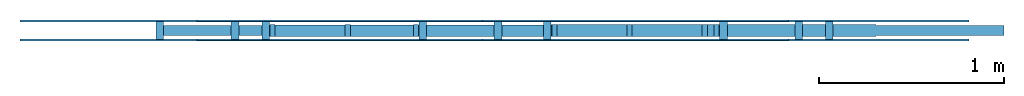
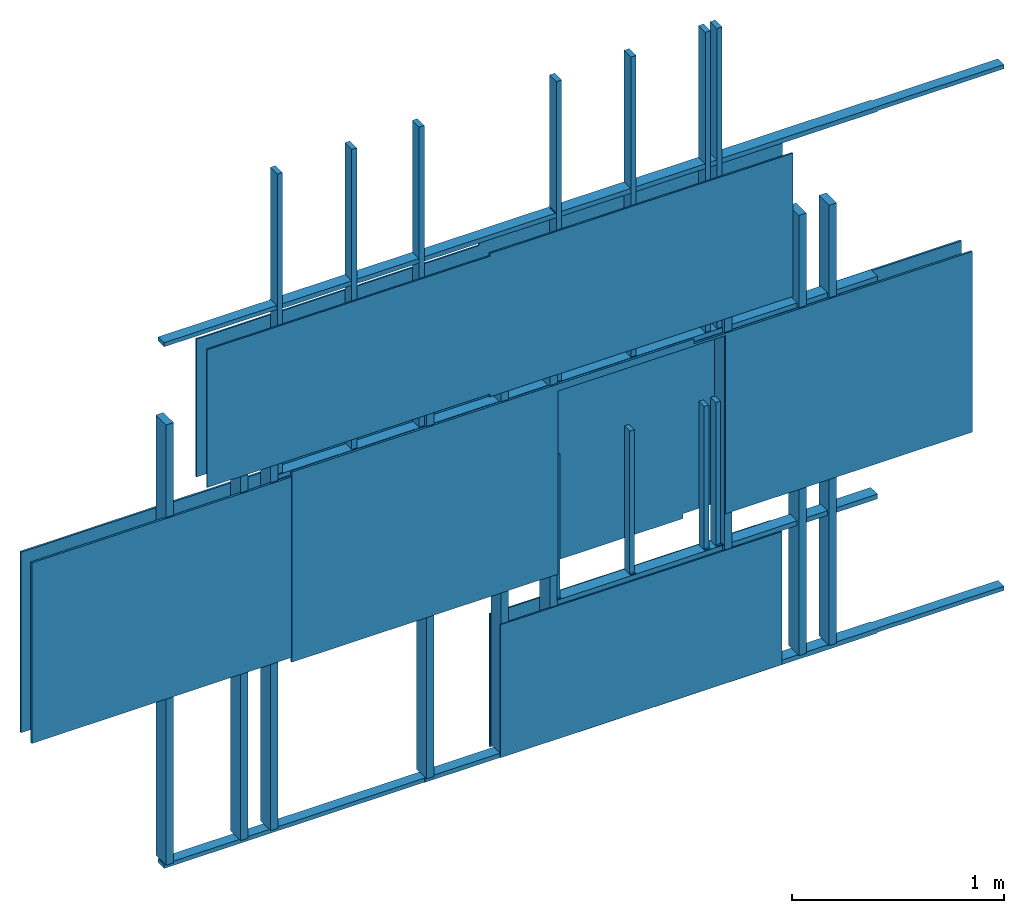
# Not in any storey: 2 building element parts, 2 members, 2 openings, 2 elements without a shape of their own.
"""IFC4 model written with IfcOpenShell, lengths in inches."""

from ifc_helpers import new_model, entity, si_unit, converted_unit, frame, frame_2d, origin, place, context, project, spatial, rectangle, extrude, source, transform, mapped, material, material_profile, profile_set, profile_usage, type_object, type_shapes, element, aggregate, save


model = new_model("IFC4")

# Units and contexts
model_context = context("Model", 3, precision=1e-05, world=origin())
plan_context = context("Plan", 2, precision=1e-05, world=origin())
ifc_project = project(units=[converted_unit("AREAUNIT", "square inch", entity("IfcAreaMeasure", 0.0006452), si_unit("AREAUNIT", "SQUARE_METRE"), dimensions=[2, 0, 0, 0, 0, 0, 0]), converted_unit("LENGTHUNIT", "inch", entity("IfcLengthMeasure", 0.0254), si_unit("LENGTHUNIT", "METRE"), dimensions=[1, 0, 0, 0, 0, 0, 0]), converted_unit("MASSUNIT", "pound", entity("IfcMassMeasure", 0.45359237), si_unit("MASSUNIT", "GRAM", prefix="KILO"), dimensions=[0, 1, 0, 0, 0, 0, 0]), converted_unit("PLANEANGLEUNIT", "degree", entity("IfcPlaneAngleMeasure", 0.0174532925199433), si_unit("PLANEANGLEUNIT", "RADIAN"), dimensions=[0, 0, 0, 0, 0, 0, 0]), converted_unit("VOLUMEUNIT", "cubic inch", entity("IfcVolumeMeasure", 1.639e-05), si_unit("VOLUMEUNIT", "CUBIC_METRE"), dimensions=[3, 0, 0, 0, 0, 0, 0])], contexts=[model_context, plan_context])

# Site
site_placement = place(None, origin())
site = spatial("IfcSite", under=ifc_project, at=site_placement, CompositionType="ELEMENT")

# Wall, openings, assembly, members, building element parts
wall_type = type_object("IfcWallType", Name="Wood Framed Wall", PredefinedType="NOTDEFINED")
wall_placement = place(site_placement, frame((48.0, 48.0, 0.0), z_axis=(0.0, 0.0, 1.0), x_axis=(1.0, 0.0, 0.0)))
wall = element("IfcWallElementedCase", 1, at=wall_placement, inside=site, type_object=wall_type, Name="Wall #1", PredefinedType="MOVABLE")
opening_1_placement = place(wall_placement, frame((24.0, -2.25, 0.0)))
element("IfcOpeningElement", 2, at=opening_1_placement, cuts=wall, context=model_context, shape_type="SweptSolid", body=[
    extrude(rectangle(XDim=32.0, YDim=80.0, at=frame_2d((-16.0, 40.0))), frame((0.0, 0.0, 0.0), z_axis=(0.0, 1.0, 0.0), x_axis=(-1.0, 0.0, 0.0)), (0.0, 0.0, 1.0), 1.5),
])
opening_2_placement = place(wall_placement, frame((84.0, 0.0, 32.0), z_axis=(0.0, -1.0, 0.0), x_axis=(1.0, 0.0, 0.0)))
element("IfcOpeningElement", 3, at=opening_2_placement, cuts=wall, PredefinedType="OPENING", context=model_context, shape_type="SweptSolid", body=[
    extrude(rectangle(XDim=36.0, YDim=48.0), frame((18.0, 24.0, -1.5)), (0.0, 0.0, 1.0), 1.5),
])
element_assembly_type = type_object("IfcElementAssemblyType", Name="Wood Stud Frame", PredefinedType="NOTDEFINED")
assembly_placement = place(wall_placement, frame((0.0, 0.5, 0.0), z_axis=(0.0, -1.0, 0.0), x_axis=(1.0, 0.0, 0.0)))
assembly = element("IfcElementAssembly", 4, at=assembly_placement, type_object=element_assembly_type, Name="Frame", PredefinedType="BRACED_FRAME")
ifc_material_1 = material(Name="Southern Pine")
ifc_material_profile_1 = material_profile(ifc_material_1, rectangle(XDim=3.5, YDim=1.5))
ifc_profile_set_1 = profile_set([ifc_material_profile_1])
ifc_profile_usage_1 = profile_usage(ifc_profile_set_1)
ifc_material_2 = material(Name="Southern Pine", Category="Wood")
ifc_material_profile_2 = material_profile(ifc_material_2, rectangle(XDim=1.5, YDim=3.5))
ifc_profile_set_2 = profile_set([ifc_material_profile_2], Name="2x4 Lumber")
member_type_1 = type_object("IfcMemberType", Name="Wood Track", PredefinedType="PLATE", material=ifc_profile_set_2)
shared_shape_1 = source(origin(), model_context, "Body", "SweptSolid", [
    extrude(rectangle(XDim=1.5, YDim=3.5), frame((0.0, 0.0, 0.0), z_axis=(1.0, 0.0, 0.0), x_axis=(0.0, 1.0, 0.0)), (0.0, 0.0, 1.0), 96.0),
])
type_shapes(member_type_1, [shared_shape_1])
member_1_placement = place(assembly_placement, origin())
member_1 = element("IfcMember", 5, at=member_1_placement, type_object=member_type_1, material=ifc_profile_usage_1, Name="Track", PredefinedType="PLATE", context=model_context, shape_type="MappedRepresentation", body=[
    mapped(shared_shape_1, transform((0.0, 0.75, -1.75), scale=0.25, scale2=1.0, scale3=1.0, uniform=False)),
    mapped(shared_shape_1, transform((0.0, 119.25, -1.75), scale=0.25, scale2=1.0, scale3=1.0, uniform=False)),
    mapped(shared_shape_1, transform((24.0, 80.75, -1.75), scale=0.333333333333333, scale2=1.0, scale3=1.0, uniform=False)),
    mapped(shared_shape_1, transform((24.0, 119.25, -1.75), scale=0.333333333333333, scale2=1.0, scale3=1.0, uniform=False)),
    mapped(shared_shape_1, transform((56.0, 0.75, -1.75), scale=0.291666666666667, scale2=1.0, scale3=1.0, uniform=False)),
    mapped(shared_shape_1, transform((56.0, 119.25, -1.75), scale=0.291666666666667, scale2=1.0, scale3=1.0, uniform=False)),
    mapped(shared_shape_1, transform((84.0, 0.75, -1.75), scale=0.375, scale2=1.0, scale3=1.0, uniform=False)),
    mapped(shared_shape_1, transform((84.0, 31.25, -1.75), scale=0.375, scale2=1.0, scale3=1.0, uniform=False)),
    mapped(shared_shape_1, transform((84.0, 80.75, -1.75), scale=0.375, scale2=1.0, scale3=1.0, uniform=False)),
    mapped(shared_shape_1, transform((84.0, 119.25, -1.75), scale=0.375, scale2=1.0, scale3=1.0, uniform=False)),
    mapped(shared_shape_1, transform((120.0, 0.75, -1.75), scale=0.25, scale2=1.0, scale3=1.0, uniform=False)),
    mapped(shared_shape_1, transform((120.0, 119.25, -1.75), scale=0.25, scale2=1.0, scale3=1.0, uniform=False)),
])
ifc_material_3 = material(Name="Southern Pine")
ifc_material_profile_3 = material_profile(ifc_material_3, rectangle(XDim=1.5, YDim=3.5))
ifc_profile_set_3 = profile_set([ifc_material_profile_3])
ifc_profile_usage_2 = profile_usage(ifc_profile_set_3)
member_type_2 = type_object("IfcMemberType", Name="Wood Stud", PredefinedType="STUD", material=ifc_profile_set_2)
shared_shape_2 = source(origin(), model_context, "Body", "SweptSolid", [
    extrude(rectangle(XDim=1.5, YDim=3.5), frame((0.0, 0.0, 0.0), z_axis=(1.0, 0.0, 0.0), x_axis=(0.0, 1.0, 0.0)), (0.0, 0.0, 1.0), 92.5),
])
type_shapes(member_type_2, [shared_shape_2])
member_2_placement = place(assembly_placement, origin())
member_2 = element("IfcMember", 6, at=member_2_placement, type_object=member_type_2, material=ifc_profile_usage_2, Name="Studs", PredefinedType="STUD", context=model_context, shape_type="MappedRepresentation", body=[
    mapped(shared_shape_2, transform((0.75, 1.5, -1.75), x_axis=(0.0, 1.0, 0.0), y_axis=(1.0, 0.0, 0.0), z_axis=(0.0, 0.0, 1.0), scale=1.26486486486486, scale2=1.0, scale3=1.0, uniform=False)),
    mapped(shared_shape_2, transform((16.75, 1.5, -1.75), x_axis=(0.0, 1.0, 0.0), y_axis=(1.0, 0.0, 0.0), z_axis=(0.0, 0.0, 1.0), scale=1.26486486486486, scale2=1.0, scale3=1.0, uniform=False)),
    mapped(shared_shape_2, transform((23.25, 1.5, -1.75), x_axis=(0.0, 1.0, 0.0), y_axis=(1.0, 0.0, 0.0), z_axis=(0.0, 0.0, 1.0), scale=1.26486486486486, scale2=1.0, scale3=1.0, uniform=False)),
    mapped(shared_shape_2, transform((24.75, 81.5, -1.75), x_axis=(0.0, 1.0, 0.0), y_axis=(1.0, 0.0, 0.0), z_axis=(0.0, 0.0, 1.0), scale=0.4, scale2=1.0, scale3=1.0, uniform=False)),
    mapped(shared_shape_2, transform((40.75, 81.5, -1.75), x_axis=(0.0, 1.0, 0.0), y_axis=(1.0, 0.0, 0.0), z_axis=(0.0, 0.0, 1.0), scale=0.4, scale2=1.0, scale3=1.0, uniform=False)),
    mapped(shared_shape_2, transform((55.25, 81.5, -1.75), x_axis=(0.0, 1.0, 0.0), y_axis=(1.0, 0.0, 0.0), z_axis=(0.0, 0.0, 1.0), scale=0.4, scale2=1.0, scale3=1.0, uniform=False)),
    mapped(shared_shape_2, transform((56.75, 1.5, -1.75), x_axis=(0.0, 1.0, 0.0), y_axis=(1.0, 0.0, 0.0), z_axis=(0.0, 0.0, 1.0), scale=1.26486486486486, scale2=1.0, scale3=1.0, uniform=False)),
    mapped(shared_shape_2, transform((72.75, 1.5, -1.75), x_axis=(0.0, 1.0, 0.0), y_axis=(1.0, 0.0, 0.0), z_axis=(0.0, 0.0, 1.0), scale=1.26486486486486, scale2=1.0, scale3=1.0, uniform=False)),
    mapped(shared_shape_2, transform((83.25, 1.5, -1.75), x_axis=(0.0, 1.0, 0.0), y_axis=(1.0, 0.0, 0.0), z_axis=(0.0, 0.0, 1.0), scale=1.26486486486486, scale2=1.0, scale3=1.0, uniform=False)),
    mapped(shared_shape_2, transform((84.75, 1.5, -1.75), x_axis=(0.0, 1.0, 0.0), y_axis=(1.0, 0.0, 0.0), z_axis=(0.0, 0.0, 1.0), scale=0.313513513513514, scale2=1.0, scale3=1.0, uniform=False)),
    mapped(shared_shape_2, transform((100.75, 1.5, -1.75), x_axis=(0.0, 1.0, 0.0), y_axis=(1.0, 0.0, 0.0), z_axis=(0.0, 0.0, 1.0), scale=0.313513513513514, scale2=1.0, scale3=1.0, uniform=False)),
    mapped(shared_shape_2, transform((116.75, 1.5, -1.75), x_axis=(0.0, 1.0, 0.0), y_axis=(1.0, 0.0, 0.0), z_axis=(0.0, 0.0, 1.0), scale=0.313513513513514, scale2=1.0, scale3=1.0, uniform=False)),
    mapped(shared_shape_2, transform((119.25, 1.5, -1.75), x_axis=(0.0, 1.0, 0.0), y_axis=(1.0, 0.0, 0.0), z_axis=(0.0, 0.0, 1.0), scale=0.313513513513514, scale2=1.0, scale3=1.0, uniform=False)),
    mapped(shared_shape_2, transform((84.75, 81.5, -1.75), x_axis=(0.0, 1.0, 0.0), y_axis=(1.0, 0.0, 0.0), z_axis=(0.0, 0.0, 1.0), scale=0.4, scale2=1.0, scale3=1.0, uniform=False)),
    mapped(shared_shape_2, transform((100.75, 81.5, -1.75), x_axis=(0.0, 1.0, 0.0), y_axis=(1.0, 0.0, 0.0), z_axis=(0.0, 0.0, 1.0), scale=0.4, scale2=1.0, scale3=1.0, uniform=False)),
    mapped(shared_shape_2, transform((116.75, 81.5, -1.75), x_axis=(0.0, 1.0, 0.0), y_axis=(1.0, 0.0, 0.0), z_axis=(0.0, 0.0, 1.0), scale=0.4, scale2=1.0, scale3=1.0, uniform=False)),
    mapped(shared_shape_2, transform((119.25, 81.5, -1.75), x_axis=(0.0, 1.0, 0.0), y_axis=(1.0, 0.0, 0.0), z_axis=(0.0, 0.0, 1.0), scale=0.4, scale2=1.0, scale3=1.0, uniform=False)),
    mapped(shared_shape_2, transform((120.75, 1.5, -1.75), x_axis=(0.0, 1.0, 0.0), y_axis=(1.0, 0.0, 0.0), z_axis=(0.0, 0.0, 1.0), scale=1.26486486486486, scale2=1.0, scale3=1.0, uniform=False)),
    mapped(shared_shape_2, transform((136.75, 1.5, -1.75), x_axis=(0.0, 1.0, 0.0), y_axis=(1.0, 0.0, 0.0), z_axis=(0.0, 0.0, 1.0), scale=1.26486486486486, scale2=1.0, scale3=1.0, uniform=False)),
    mapped(shared_shape_2, transform((143.25, 1.5, -1.75), x_axis=(0.0, 1.0, 0.0), y_axis=(1.0, 0.0, 0.0), z_axis=(0.0, 0.0, 1.0), scale=1.26486486486486, scale2=1.0, scale3=1.0, uniform=False)),
])
aggregate(assembly, [member_1, member_2])
building_element_part_type = type_object("IfcBuildingElementPartType", Name="Drywall", PredefinedType="PRECASTPANEL")
shared_shape_3 = source(origin(), model_context, "Body", "SweptSolid", [
    extrude(rectangle(XDim=96.0, YDim=48.0), frame((48.0, 24.0, 0.0), z_axis=(0.0, 0.0, 1.0), x_axis=(1.0, 0.0, 0.0)), (0.0, 0.0, 1.0), 0.5),
])
type_shapes(building_element_part_type, [shared_shape_3])
building_element_part_1_placement = place(wall_placement, frame((0.0, 0.0, 0.0), z_axis=(0.0, -1.0, 0.0), x_axis=(1.0, 0.0, 0.0)))
building_element_part_1 = element("IfcBuildingElementPart", 7, at=building_element_part_1_placement, type_object=building_element_part_type, Name="Panel Forward", PredefinedType="PRECASTPANEL", context=model_context, shape_type="MappedRepresentation", body=[
    mapped(shared_shape_3, transform((0.0, 0.0, -0.5), scale=0.25, scale2=2.5, scale3=1.0, uniform=False)),
    mapped(shared_shape_3, transform((24.0, 80.0, -0.5), scale=0.333333333333333, scale2=0.833333333333333, scale3=1.0, uniform=False)),
    mapped(shared_shape_3, transform((56.0, 0.0, -0.5), scale=0.291666666666667, scale2=2.5, scale3=1.0, uniform=False)),
    mapped(shared_shape_3, transform((84.0, 0.0, -0.5), scale=0.375, scale2=0.666666666666667, scale3=1.0, uniform=False)),
    mapped(shared_shape_3, transform((84.0, 80.0, -0.5), scale=0.375, scale2=0.833333333333333, scale3=1.0, uniform=False)),
    mapped(shared_shape_3, transform((120.0, 0.0, -0.5), scale=0.25, scale2=2.5, scale3=1.0, uniform=False)),
])
building_element_part_2_placement = place(wall_placement, frame((0.0, 4.0, 0.0), z_axis=(0.0, -1.0, 0.0), x_axis=(1.0, 0.0, 0.0)))
building_element_part_2 = element("IfcBuildingElementPart", 8, at=building_element_part_2_placement, type_object=building_element_part_type, Name="Panel Reverse", PredefinedType="PRECASTPANEL", context=model_context, shape_type="MappedRepresentation", body=[
    mapped(shared_shape_3, transform((0.0, 0.0, -0.5), scale=0.25, scale2=2.5, scale3=1.0, uniform=False)),
    mapped(shared_shape_3, transform((24.0, 80.0, -0.5), scale=0.333333333333333, scale2=0.833333333333333, scale3=1.0, uniform=False)),
    mapped(shared_shape_3, transform((56.0, 0.0, -0.5), scale=0.291666666666667, scale2=2.5, scale3=1.0, uniform=False)),
    mapped(shared_shape_3, transform((84.0, 0.0, -0.5), scale=0.375, scale2=0.666666666666667, scale3=1.0, uniform=False)),
    mapped(shared_shape_3, transform((84.0, 80.0, -0.5), scale=0.375, scale2=0.833333333333333, scale3=1.0, uniform=False)),
    mapped(shared_shape_3, transform((120.0, 0.0, -0.5), scale=0.25, scale2=2.5, scale3=1.0, uniform=False)),
])
aggregate(wall, [building_element_part_1, building_element_part_2, assembly])

save(model, "model.ifc")
